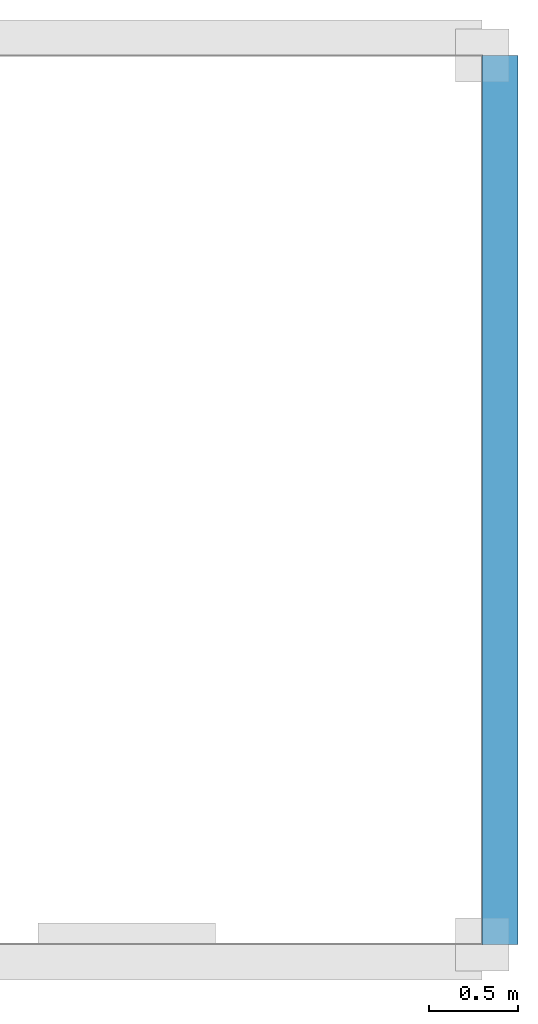
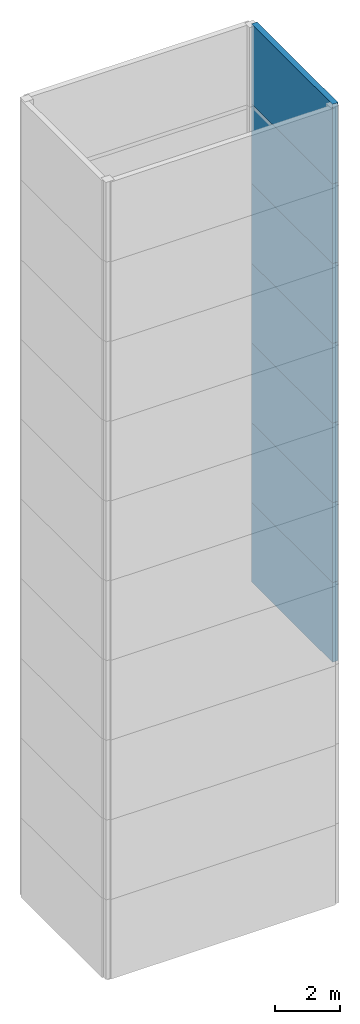
# Not in any storey, part 2 of 3: 7 walls.
"""IFC4 model written with IfcOpenShell, lengths in metres."""

from ifc_helpers import new_model, si_unit, origin_with_axes, place, context, project, faceted_brep, element, save


model = new_model("IFC4")

# Units and contexts
model_context = context("Model", 3, precision=1e-05, world=origin_with_axes())
ifc_project = project(units=[si_unit("LENGTHUNIT", "METRE"), si_unit("AREAUNIT", "SQUARE_METRE"), si_unit("VOLUMEUNIT", "CUBIC_METRE")], contexts=[model_context])

# Walls
wall_1_placement = place(None, origin_with_axes())
element("IfcWall", 1, at=wall_1_placement, context=model_context, shape_type="Brep", body=[
    faceted_brep([(8.0, 0.0, 9.0), (8.2, 0.0, 9.0), (8.2, 5.0, 9.0), (8.0, 5.0, 9.0), (8.0, 0.0, 12.0), (8.0, 5.0, 12.0), (8.2, 5.0, 12.0), (8.2, 0.0, 12.0)], [[[0, 1, 2, 3]], [[4, 5, 6, 7]], [[0, 3, 5, 4]], [[1, 7, 6, 2]], [[0, 4, 7, 1]], [[3, 2, 6, 5]]]),
])
wall_2_placement = place(None, origin_with_axes())
element("IfcWall", 2, at=wall_2_placement, context=model_context, shape_type="Brep", body=[
    faceted_brep([(8.0, 0.0, 12.0), (8.2, 0.0, 12.0), (8.2, 5.0, 12.0), (8.0, 5.0, 12.0), (8.0, 0.0, 15.0), (8.0, 5.0, 15.0), (8.2, 5.0, 15.0), (8.2, 0.0, 15.0)], [[[0, 1, 2, 3]], [[4, 5, 6, 7]], [[0, 3, 5, 4]], [[1, 7, 6, 2]], [[0, 4, 7, 1]], [[3, 2, 6, 5]]]),
])
wall_3_placement = place(None, origin_with_axes())
element("IfcWall", 3, at=wall_3_placement, context=model_context, shape_type="Brep", body=[
    faceted_brep([(8.0, 0.0, 15.0), (8.2, 0.0, 15.0), (8.2, 5.0, 15.0), (8.0, 5.0, 15.0), (8.0, 0.0, 18.0), (8.0, 5.0, 18.0), (8.2, 5.0, 18.0), (8.2, 0.0, 18.0)], [[[0, 1, 2, 3]], [[4, 5, 6, 7]], [[0, 3, 5, 4]], [[1, 7, 6, 2]], [[0, 4, 7, 1]], [[3, 2, 6, 5]]]),
])
wall_4_placement = place(None, origin_with_axes())
element("IfcWall", 4, at=wall_4_placement, context=model_context, shape_type="Brep", body=[
    faceted_brep([(8.0, 0.0, 18.0), (8.2, 0.0, 18.0), (8.2, 5.0, 18.0), (8.0, 5.0, 18.0), (8.0, 0.0, 21.0), (8.0, 5.0, 21.0), (8.2, 5.0, 21.0), (8.2, 0.0, 21.0)], [[[0, 1, 2, 3]], [[4, 5, 6, 7]], [[0, 3, 5, 4]], [[1, 7, 6, 2]], [[0, 4, 7, 1]], [[3, 2, 6, 5]]]),
])
wall_5_placement = place(None, origin_with_axes())
element("IfcWall", 5, at=wall_5_placement, context=model_context, shape_type="Brep", body=[
    faceted_brep([(8.0, 0.0, 21.0), (8.2, 0.0, 21.0), (8.2, 5.0, 21.0), (8.0, 5.0, 21.0), (8.0, 0.0, 24.0), (8.0, 5.0, 24.0), (8.2, 5.0, 24.0), (8.2, 0.0, 24.0)], [[[0, 1, 2, 3]], [[4, 5, 6, 7]], [[0, 3, 5, 4]], [[1, 7, 6, 2]], [[0, 4, 7, 1]], [[3, 2, 6, 5]]]),
])
wall_6_placement = place(None, origin_with_axes())
element("IfcWall", 6, at=wall_6_placement, context=model_context, shape_type="Brep", body=[
    faceted_brep([(8.0, 0.0, 24.0), (8.2, 0.0, 24.0), (8.2, 5.0, 24.0), (8.0, 5.0, 24.0), (8.0, 0.0, 27.0), (8.0, 5.0, 27.0), (8.2, 5.0, 27.0), (8.2, 0.0, 27.0)], [[[0, 1, 2, 3]], [[4, 5, 6, 7]], [[0, 3, 5, 4]], [[1, 7, 6, 2]], [[0, 4, 7, 1]], [[3, 2, 6, 5]]]),
])
wall_7_placement = place(None, origin_with_axes())
element("IfcWall", 7, at=wall_7_placement, context=model_context, shape_type="Brep", body=[
    faceted_brep([(8.0, 0.0, 27.0), (8.2, 0.0, 27.0), (8.2, 5.0, 27.0), (8.0, 5.0, 27.0), (8.0, 0.0, 30.0), (8.0, 5.0, 30.0), (8.2, 5.0, 30.0), (8.2, 0.0, 30.0)], [[[0, 1, 2, 3]], [[4, 5, 6, 7]], [[0, 3, 5, 4]], [[1, 7, 6, 2]], [[0, 4, 7, 1]], [[3, 2, 6, 5]]]),
])

save(model, "model.ifc")
